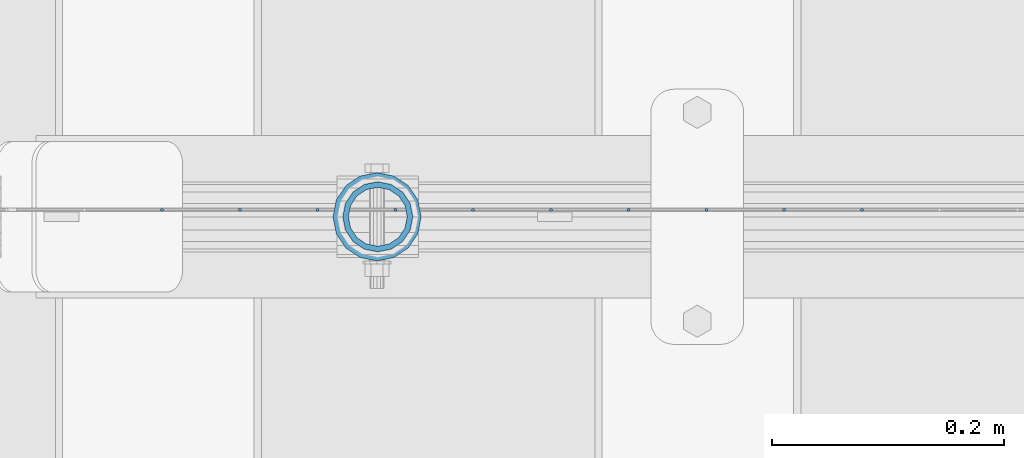
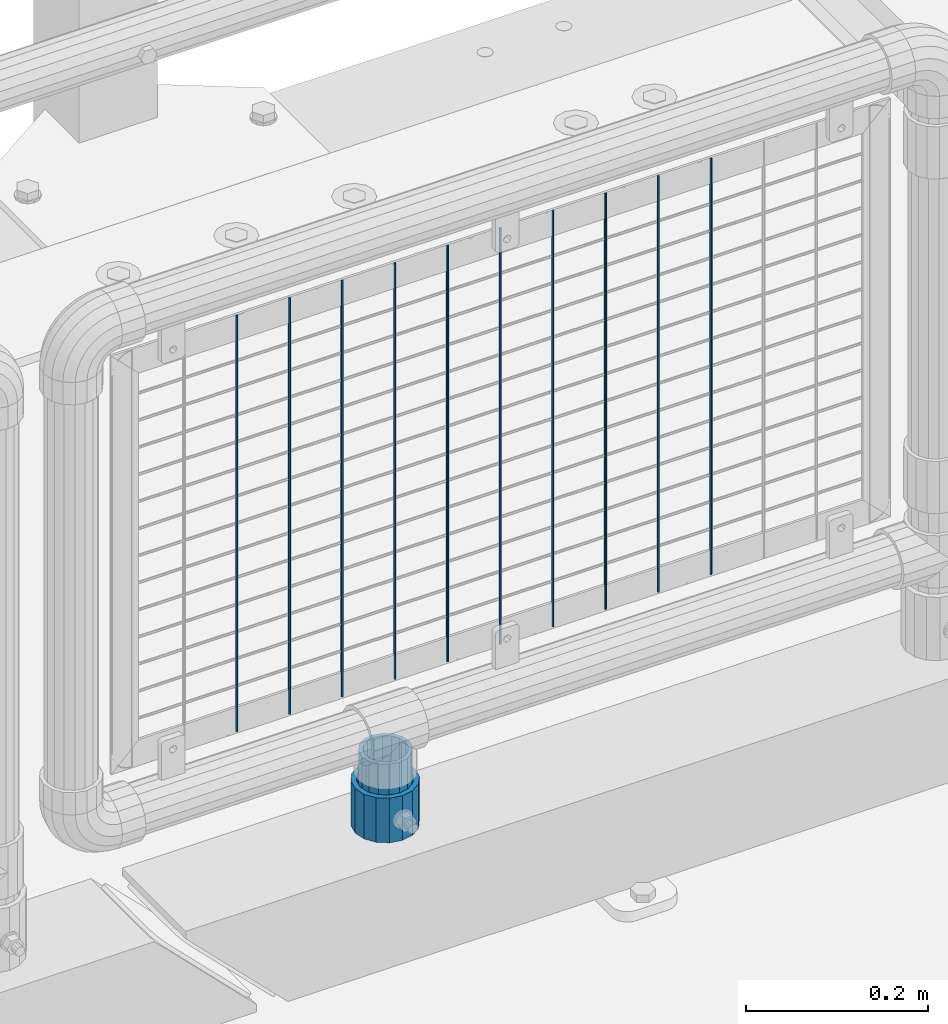
# One storey, part 97 of 257: 12 columns.
"""IFC2X3 building model written with IfcOpenShell, lengths in millimetres."""

import ifcopenshell
import ifcopenshell.guid

model = None  # the IFC model being written
_history = None  # IfcOwnerHistory: only IFC2X3 demands one
_inside = {}  # id of a spatial element -> (the spatial element, [elements in it])
_under = {}  # id of a project, library or spatial element -> (it, [spatial elements below it])
_declared = {}  # id of a project -> (the project, [libraries it declares])
_typed = {}  # id of a type object -> (the type object, [elements of that type])
_made_of = {}  # id of a material, layer set ... -> (it, [elements and type objects made of it])


def new_model(schema):
    """Start an empty IFC model of exactly this schema.

    Asked for "IFC4X3", IfcOpenShell would pick the latest addendum, in which some entities
    have other attributes; the version numbers below select the first issue.
    IFC2X3 requires an IfcOwnerHistory on every rooted entity: one is made here for all.
    """
    global model, _history
    if schema == "IFC4X3":
        model = ifcopenshell.file(schema_version=(4, 3, 0, 0))
    else:
        model = ifcopenshell.file(schema=schema)
    _inside.clear()
    _under.clear()
    _declared.clear()
    _typed.clear()
    _made_of.clear()
    _history = None
    if model.schema == "IFC2X3":
        org = make("IfcOrganization", Name="unknown")
        user = make(
            "IfcPersonAndOrganization",
            ThePerson=make("IfcPerson", FamilyName="unknown"),
            TheOrganization=org,
        )
        app = make(
            "IfcApplication",
            ApplicationDeveloper=org,
            Version="unknown",
            ApplicationFullName="unknown",
            ApplicationIdentifier="unknown",
        )
        _history = make(
            "IfcOwnerHistory",
            OwningUser=user,
            OwningApplication=app,
            ChangeAction="ADDED",
            CreationDate=0,
        )
    return model


def make(cls, **values):
    """One entity of the class cls with the attributes given. An attribute that is None is left unset."""
    return model.create_entity(
        cls, **{name: value for name, value in values.items() if value is not None}
    )


def rooted(cls, **values):
    """An entity with a GlobalId (a new one), such as an element, a storey or a relation."""
    return make(cls, GlobalId=ifcopenshell.guid.new(), OwnerHistory=_history, **values)


def si_unit(unit_type, name, prefix=None):
    """IfcSIUnit, for example si_unit("LENGTHUNIT", "METRE", prefix="MILLI")."""
    return make("IfcSIUnit", UnitType=unit_type, Prefix=prefix, Name=name)


def assignment(units):
    """IfcUnitAssignment: the units of a project."""
    return None if units is None else make("IfcUnitAssignment", Units=units)


def point(xyz):
    """IfcCartesianPoint."""
    return None if xyz is None else make("IfcCartesianPoint", Coordinates=xyz)


def direction(xyz):
    """IfcDirection."""
    return None if xyz is None else make("IfcDirection", DirectionRatios=xyz)


def frame(location, z_axis=None, x_axis=None):
    """IfcAxis2Placement3D, a coordinate frame: its origin and axes. An axis left out is left unset."""
    return make(
        "IfcAxis2Placement3D",
        Location=point(location),
        Axis=direction(z_axis),
        RefDirection=direction(x_axis),
    )


def origin_with_axes():
    """The frame at (0, 0, 0) with the z axis (0, 0, 1) and the x axis (1, 0, 0) written out."""
    return frame((0.0, 0.0, 0.0), z_axis=(0.0, 0.0, 1.0), x_axis=(1.0, 0.0, 0.0))


def place(relative_to, where):
    """IfcLocalPlacement: puts the frame where relative to a parent placement (None: the world)."""
    return make(
        "IfcLocalPlacement", PlacementRelTo=relative_to, RelativePlacement=where
    )


def context(
    kind, dimensions, precision=None, world=None, true_north=None, identifier=None
):
    """IfcGeometricRepresentationContext, for example the 3D "Model" context."""
    return make(
        "IfcGeometricRepresentationContext",
        ContextIdentifier=identifier,
        ContextType=kind,
        CoordinateSpaceDimension=dimensions,
        Precision=precision,
        WorldCoordinateSystem=world,
        TrueNorth=true_north,
    )


def subcontext(parent, identifier, kind, view, scale=None):
    """IfcGeometricRepresentationSubContext, for example "Body" below "Model"."""
    return make(
        "IfcGeometricRepresentationSubContext",
        ContextIdentifier=identifier,
        ContextType=kind,
        ParentContext=parent,
        TargetScale=scale,
        TargetView=view,
    )


def project(units=None, contexts=None):
    """IfcProject with its units and contexts."""
    return rooted(
        "IfcProject",
        Name="project",
        RepresentationContexts=contexts,
        UnitsInContext=assignment(units),
    )


def spatial(cls, under=None, at=None, **own):
    """A site, building, storey or space (cls), placed at a placement, below another one or the project."""
    s = rooted(cls, ObjectPlacement=at, **own)
    if under is not None:
        _under.setdefault(under.id(), (under, []))[1].append(s)
    return s


def faces_of(points, faces, orient=None, outer=None):
    """IfcFace entities. A face is a list of loops; a loop is a list of indices into points, from 0.

    orient and outer hold one flag for each loop. By default every Orientation is true, the
    first loop of a face is its IfcFaceOuterBound and the others are IfcFaceBound.
    """
    made = []
    for i, loops in enumerate(faces):
        bounds = []
        for j, loop in enumerate(loops):
            is_outer = j == 0 if outer is None else outer[i][j]
            bounds.append(
                make(
                    "IfcFaceOuterBound" if is_outer else "IfcFaceBound",
                    Bound=make("IfcPolyLoop", Polygon=[points[k] for k in loop]),
                    Orientation=True if orient is None else orient[i][j],
                )
            )
        made.append(make("IfcFace", Bounds=bounds))
    return made


def faceted_brep(points, faces, orient=None, outer=None, voids=None):
    """IfcFacetedBrep: a solid bounded by flat faces; with voids (closed shells), ...WithVoids."""
    shared = [point(p) for p in points]
    hull = make("IfcClosedShell", CfsFaces=faces_of(shared, faces, orient, outer))
    if voids is None:
        return make("IfcFacetedBrep", Outer=hull)
    return make(
        "IfcFacetedBrepWithVoids",
        Outer=hull,
        Voids=[
            make(cls, CfsFaces=faces_of(shared, fs, o, b)) for cls, fs, o, b in voids
        ],
    )


def shape(context_of_items, identifier, shape_type, items):
    """IfcShapeRepresentation: the items that make up one representation, for example the "Body"."""
    return make(
        "IfcShapeRepresentation",
        ContextOfItems=context_of_items,
        RepresentationIdentifier=identifier,
        RepresentationType=shape_type,
        Items=items,
    )


def material(Name=None, Category=None):
    """IfcMaterial."""
    return make("IfcMaterial", Name=Name, Category=Category)


def made_of(thing, what):
    """Note that an element or type object is made of a material, layer set ...; save() writes the relation."""
    if what is not None:
        _made_of.setdefault(what.id(), (what, []))[1].append(thing)
    return thing


def type_object(cls, material=None, **own):
    """A type object (cls), such as IfcWallType, which elements share."""
    return made_of(rooted(cls, **own), material)


def element(
    cls,
    number,
    at=None,
    inside=None,
    cuts=None,
    type_object=None,
    material=None,
    context=None,
    identifier="Body",
    shape_type=None,
    held_by="IfcProductDefinitionShape",
    body=None,
    shapes=None,
    **own,
):
    """One element of the class cls, such as IfcWall. Its Tag is "e" and its number.

    at: its placement. inside: the storey or other place that contains it. cuts: it is an
    opening in that element (IfcRelVoidsElement). A single representation is given by context,
    identifier, shape_type and body (its items); several are given by shapes. held_by: the class
    of the entity that holds the representations. save() writes the other relations.
    """
    e = rooted(cls, Tag="e%d" % number, ObjectPlacement=at, **own)
    if body is not None:
        shapes = [shape(context, identifier, shape_type, body)]
    if shapes is not None:
        e.Representation = make(held_by, Representations=shapes)
    if inside is not None:
        _inside.setdefault(inside.id(), (inside, []))[1].append(e)
    if cuts is not None:
        rooted(
            "IfcRelVoidsElement", RelatingBuildingElement=cuts, RelatedOpeningElement=e
        )
    if type_object is not None:
        _typed.setdefault(type_object.id(), (type_object, []))[1].append(e)
    return made_of(e, material)


def aggregate(whole, parts):
    """IfcRelAggregates: a whole, such as a stair, and the parts it consists of."""
    return rooted("IfcRelAggregates", RelatingObject=whole, RelatedObjects=parts)


def save(model, path):
    """Write the relations noted so far, then the file.

    IfcRelAggregates (storeys below a building ...), IfcRelContainedInSpatialStructure (elements
    in a storey), IfcRelDefinesByType, IfcRelAssociatesMaterial and IfcRelDeclares: one each for
    every whole, place, type object, material and project.
    """
    for whole, parts in _under.values():
        aggregate(whole, parts)
    for where, things in _inside.values():
        rooted(
            "IfcRelContainedInSpatialStructure",
            RelatedElements=things,
            RelatingStructure=where,
        )
    for kind, things in _typed.values():
        rooted("IfcRelDefinesByType", RelatedObjects=things, RelatingType=kind)
    for what, things in _made_of.values():
        rooted("IfcRelAssociatesMaterial", RelatedObjects=things, RelatingMaterial=what)
    for by, libraries in _declared.values():
        rooted("IfcRelDeclares", RelatingContext=by, RelatedDefinitions=libraries)
    model.write(path)


model = new_model("IFC2X3")

# Units and contexts
model_context = context("Model", 3, precision=1e-05, world=origin_with_axes())
body_context = subcontext(model_context, "Body", "Model", "MODEL_VIEW")
ifc_project = project(units=[si_unit("LENGTHUNIT", "METRE", prefix="MILLI"), si_unit("AREAUNIT", "SQUARE_METRE"), si_unit("VOLUMEUNIT", "CUBIC_METRE"), si_unit("MASSUNIT", "GRAM", prefix="KILO"), si_unit("TIMEUNIT", "SECOND"), si_unit("PLANEANGLEUNIT", "RADIAN"), si_unit("SOLIDANGLEUNIT", "STERADIAN"), si_unit("THERMODYNAMICTEMPERATUREUNIT", "DEGREE_CELSIUS"), si_unit("LUMINOUSINTENSITYUNIT", "LUMEN")], contexts=[model_context])

# Site, building, storey
site_placement = place(None, origin_with_axes())
site = spatial("IfcSite", under=ifc_project, at=site_placement, CompositionType="ELEMENT")
building_placement = place(site_placement, origin_with_axes())
building = spatial("IfcBuilding", under=site, at=building_placement, Name="Standard", CompositionType="ELEMENT")
storey_placement = place(building_placement, origin_with_axes())
storey = spatial("IfcBuildingStorey", under=building, at=storey_placement, Name="Undefined", CompositionType="ELEMENT", Elevation=0.0)

# Columns
ifc_material_1 = material()
column_type_1 = type_object("IfcColumnType", PredefinedType="NOTDEFINED")
column_1_placement = place(storey_placement, frame((57971.0, 10664.5, 168.019999999998), z_axis=(0.0, 1.0, 0.0), x_axis=(0.0, 0.0, 1.0)))
element("IfcColumn", 1, at=column_1_placement, inside=storey, type_object=column_type_1, material=ifc_material_1, context=body_context, shape_type="Brep", body=[
    faceted_brep([(0.0, -31.75, 0.0), (0.0, -29.3331751572332, 12.1501989775916), (60.0, -29.3331751572332, 12.1501989775916), (60.0, -31.75, 0.0), (0.0, -22.4506403026753, 22.4506403026735), (60.0, -22.4506403026753, 22.4506403026735), (0.0, -12.1501989775934, 29.3331751572332), (60.0, -12.1501989775934, 29.3331751572332), (0.0, 0.0, 31.75), (60.0, 0.0, 31.75), (0.0, 12.1501989775934, 29.3331751572332), (60.0, 12.1501989775934, 29.3331751572332), (0.0, 22.4506403026753, 22.4506403026735), (60.0, 22.4506403026753, 22.4506403026735), (0.0, 29.3331751572332, 12.1501989775916), (60.0, 29.3331751572332, 12.1501989775916), (0.0, 31.75, 0.0), (60.0, 31.75, 0.0), (0.0, 29.3331751572332, -12.1501989775916), (60.0, 29.3331751572332, -12.1501989775916), (0.0, 22.4506403026753, -22.4506403026735), (60.0, 22.4506403026753, -22.4506403026735), (0.0, 12.1501989775934, -29.3331751572332), (60.0, 12.1501989775934, -29.3331751572332), (0.0, 0.0, -31.75), (60.0, 0.0, -31.75), (0.0, -12.1501989775934, -29.3331751572332), (60.0, -12.1501989775934, -29.3331751572332), (0.0, -22.4506403026753, -22.4506403026735), (60.0, -22.4506403026753, -22.4506403026735), (0.0, -29.3331751572332, -12.1501989775916), (60.0, -29.3331751572332, -12.1501989775916), (0.0, -38.0500000000029, 0.0), (0.0, -35.1536162120537, -14.561104601491), (60.0, -35.1536162120537, -14.561104601491), (60.0, -38.0500000000029, 0.0), (0.0, -26.9054130241493, -26.9054130241475), (60.0, -26.9054130241493, -26.9054130241475), (0.0, -14.5611046014892, -35.1536162120537), (60.0, -14.5611046014892, -35.1536162120537), (0.0, 0.0, -38.0499999999993), (60.0, 0.0, -38.0499999999993), (0.0, 14.5611046014892, -35.1536162120537), (60.0, 14.5611046014892, -35.1536162120537), (0.0, 26.9054130241493, -26.9054130241475), (60.0, 26.9054130241493, -26.9054130241475), (0.0, 35.1536162120537, -14.561104601491), (60.0, 35.1536162120537, -14.561104601491), (0.0, 38.0500000000029, 0.0), (60.0, 38.0500000000029, 0.0), (0.0, 35.1536162120537, 14.561104601491), (60.0, 35.1536162120537, 14.561104601491), (0.0, 26.9054130241493, 26.9054130241475), (60.0, 26.9054130241493, 26.9054130241475), (0.0, 14.5611046014892, 35.1536162120537), (60.0, 14.5611046014892, 35.1536162120537), (0.0, 0.0, 38.0499999999993), (60.0, 0.0, 38.0499999999993), (0.0, -14.5611046014892, 35.1536162120537), (60.0, -14.5611046014892, 35.1536162120537), (0.0, -26.9054130241493, 26.9054130241475), (60.0, -26.9054130241493, 26.9054130241475), (0.0, -35.1536162120537, 14.561104601491), (60.0, -35.1536162120537, 14.561104601491)], [[[0, 1, 2, 3]], [[1, 4, 5, 2]], [[4, 6, 7, 5]], [[6, 8, 9, 7]], [[8, 10, 11, 9]], [[10, 12, 13, 11]], [[12, 14, 15, 13]], [[14, 16, 17, 15]], [[16, 18, 19, 17]], [[18, 20, 21, 19]], [[20, 22, 23, 21]], [[22, 24, 25, 23]], [[24, 26, 27, 25]], [[26, 28, 29, 27]], [[28, 30, 31, 29]], [[30, 0, 3, 31]], [[32, 33, 34, 35]], [[33, 36, 37, 34]], [[36, 38, 39, 37]], [[38, 40, 41, 39]], [[40, 42, 43, 41]], [[42, 44, 45, 43]], [[44, 46, 47, 45]], [[46, 48, 49, 47]], [[48, 50, 51, 49]], [[50, 52, 53, 51]], [[52, 54, 55, 53]], [[54, 56, 57, 55]], [[56, 58, 59, 57]], [[58, 60, 61, 59]], [[60, 62, 63, 61]], [[62, 32, 35, 63]], [[37, 39, 41, 43, 45, 47, 49, 51, 53, 55, 57, 59, 61, 63, 35, 34], [5, 7, 9, 11, 13, 15, 17, 19, 21, 23, 25, 27, 29, 31, 3, 2]], [[62, 60, 58, 56, 54, 52, 50, 48, 46, 44, 42, 40, 38, 36, 33, 32], [30, 28, 26, 24, 22, 20, 18, 16, 14, 12, 10, 8, 6, 4, 1, 0]]]),
])
column_type_2 = type_object("IfcColumnType", PredefinedType="NOTDEFINED")
column_2_placement = place(storey_placement, frame((57971.61, 10664.5, 168.02), z_axis=(-1.0, 0.0, 0.0), x_axis=(0.0, 0.0, 1.0)))
element("IfcColumn", 2, at=column_2_placement, inside=storey, type_object=column_type_2, material=ifc_material_1, context=body_context, shape_type="Brep", body=[
    faceted_brep([(0.0, -25.3500000000004, 0.0), (0.0, -23.4203461491616, 9.70102501045767), (100.0, -23.4203461491616, 9.70102501045767), (100.0, -25.3500000000004, 0.0), (0.0, -17.9251569030785, 17.9251569030821), (100.0, -17.9251569030785, 17.9251569030821), (0.0, -9.70102501045585, 23.4203461491634), (100.0, -9.70102501045585, 23.4203461491634), (0.0, 0.0, 25.3499999999985), (100.0, 0.0, 25.3499999999985), (0.0, 9.70102501045585, 23.4203461491634), (100.0, 9.70102501045585, 23.4203461491634), (0.0, 17.9251569030785, 17.9251569030821), (100.0, 17.9251569030785, 17.9251569030821), (0.0, 23.4203461491616, 9.70102501045767), (100.0, 23.4203461491616, 9.70102501045767), (0.0, 25.3500000000004, 0.0), (100.0, 25.3500000000004, 0.0), (0.0, 23.4203461491616, -9.70102501045767), (100.0, 23.4203461491616, -9.70102501045767), (0.0, 17.9251569030785, -17.9251569030821), (100.0, 17.9251569030785, -17.9251569030821), (0.0, 9.70102501045585, -23.4203461491634), (100.0, 9.70102501045585, -23.4203461491634), (0.0, 0.0, -25.3499999999985), (100.0, 0.0, -25.3499999999985), (0.0, -9.70102501045585, -23.4203461491634), (100.0, -9.70102501045585, -23.4203461491634), (0.0, -17.9251569030785, -17.9251569030821), (100.0, -17.9251569030785, -17.9251569030821), (0.0, -23.4203461491616, -9.70102501045767), (100.0, -23.4203461491616, -9.70102501045767), (0.0, -30.1499999999996, 0.0), (0.0, -27.8549679052157, -11.5379054858058), (100.0, -27.8549679052157, -11.5379054858058), (100.0, -30.1499999999996, 0.0), (0.0, -21.3192694527752, -21.3192694527752), (100.0, -21.3192694527752, -21.3192694527752), (0.0, -11.5379054858076, -27.8549679052157), (100.0, -11.5379054858076, -27.8549679052157), (0.0, 0.0, -30.1500000000015), (100.0, 0.0, -30.1500000000015), (0.0, 11.5379054858076, -27.8549679052157), (100.0, 11.5379054858076, -27.8549679052157), (0.0, 21.3192694527752, -21.3192694527752), (100.0, 21.3192694527752, -21.3192694527752), (0.0, 27.8549679052157, -11.5379054858058), (100.0, 27.8549679052157, -11.5379054858058), (0.0, 30.1499999999996, 0.0), (100.0, 30.1499999999996, 0.0), (0.0, 27.8549679052157, 11.5379054858058), (100.0, 27.8549679052157, 11.5379054858058), (0.0, 21.3192694527752, 21.3192694527752), (100.0, 21.3192694527752, 21.3192694527752), (0.0, 11.5379054858076, 27.8549679052157), (100.0, 11.5379054858076, 27.8549679052157), (0.0, 0.0, 30.1500000000015), (100.0, 0.0, 30.1500000000015), (0.0, -11.5379054858076, 27.8549679052157), (100.0, -11.5379054858076, 27.8549679052157), (0.0, -21.3192694527752, 21.3192694527752), (100.0, -21.3192694527752, 21.3192694527752), (0.0, -27.8549679052157, 11.5379054858058), (100.0, -27.8549679052157, 11.5379054858058)], [[[0, 1, 2, 3]], [[1, 4, 5, 2]], [[4, 6, 7, 5]], [[6, 8, 9, 7]], [[8, 10, 11, 9]], [[10, 12, 13, 11]], [[12, 14, 15, 13]], [[14, 16, 17, 15]], [[16, 18, 19, 17]], [[18, 20, 21, 19]], [[20, 22, 23, 21]], [[22, 24, 25, 23]], [[24, 26, 27, 25]], [[26, 28, 29, 27]], [[28, 30, 31, 29]], [[30, 0, 3, 31]], [[32, 33, 34, 35]], [[33, 36, 37, 34]], [[36, 38, 39, 37]], [[38, 40, 41, 39]], [[40, 42, 43, 41]], [[42, 44, 45, 43]], [[44, 46, 47, 45]], [[46, 48, 49, 47]], [[48, 50, 51, 49]], [[50, 52, 53, 51]], [[52, 54, 55, 53]], [[54, 56, 57, 55]], [[56, 58, 59, 57]], [[58, 60, 61, 59]], [[60, 62, 63, 61]], [[62, 32, 35, 63]], [[37, 39, 41, 43, 45, 47, 49, 51, 53, 55, 57, 59, 61, 63, 35, 34], [5, 7, 9, 11, 13, 15, 17, 19, 21, 23, 25, 27, 29, 31, 3, 2]], [[62, 60, 58, 56, 54, 52, 50, 48, 46, 44, 42, 40, 38, 36, 33, 32], [30, 28, 26, 24, 22, 20, 18, 16, 14, 12, 10, 8, 6, 4, 1, 0]]]),
])
ifc_material_2 = material(Name="Misc_Undefined")
column_type_3 = type_object("IfcColumnType", Name="D3", PredefinedType="NOTDEFINED")
for number, where, z_axis, x_axis in (
    (3, (58388.9180000001, 10670.4998267273, 353.02), (-1.0, 0.0, 0.0), (0.0, 0.0, 1.0)),
    (4, (58321.8900000001, 10670.4998409362, 353.02), (-1.0, 0.0, 0.0), (0.0, 0.0, 1.0)),
    (5, (58254.8620000001, 10670.499855145, 353.02), (-1.0, 0.0, 0.0), (0.0, 0.0, 1.0)),
    (6, (58187.8340000001, 10670.4998693538, 353.02), (-1.0, 0.0, 0.0), (0.0, 0.0, 1.0)),
    (7, (57986.7500000001, 10670.4999119802, 353.02), (-1.0, 0.0, 0.0), (0.0, 0.0, 1.0)),
    (8, (57919.7220000001, 10670.4999261891, 353.02), (-1.0, 0.0, 0.0), (0.0, 0.0, 1.0)),
    (9, (57852.694, 10670.4999403979, 353.02), (-1.0, 0.0, 0.0), (0.0, 0.0, 1.0)),
    (10, (58053.7780000001, 10670.4998977714, 353.02), (-1.0, 0.0, 0.0), (0.0, 0.0, 1.0)),
    (11, (57785.666, 10670.4999546067, 353.02), (-1.0, 0.0, 0.0), (0.0, 0.0, 1.0)),
    (12, (58120.8060000001, 10670.4998835626, 353.02), (-1.0, 0.0, 0.0), (0.0, 0.0, 1.0)),
):
    element("IfcColumn", number, at=place(storey_placement, frame(where, z_axis=z_axis, x_axis=x_axis)), inside=storey, type_object=column_type_3, material=ifc_material_2, ObjectType="D3", context=body_context, shape_type="Brep", body=[
        faceted_brep([(0.0, -1.5, -5.6843418860808e-14), (0.0, -0.750000000001819, -1.29903810567669), (560.0, -0.75, -1.29903810567339), (560.0, -1.5, 0.0), (7.27595761418343e-12, 0.749999999998181, -1.29903810567669), (560.0, 0.75, -1.29903810567339), (0.0, 1.5, -5.6843418860808e-14), (560.0, 1.5, 0.0), (7.27595761418343e-12, 0.749999999998181, 1.29903810567669), (560.0, 0.75, 1.29903810567339), (0.0, -0.750000000001819, 1.29903810567669), (560.0, -0.75, 1.29903810567339)], [[[0, 1, 2, 3]], [[1, 4, 5, 2]], [[4, 6, 7, 5]], [[6, 8, 9, 7]], [[8, 10, 11, 9]], [[10, 0, 3, 11]], [[5, 7, 9, 11, 3, 2]], [[10, 8, 6, 4, 1, 0]]]),
    ])

save(model, "model.ifc")
